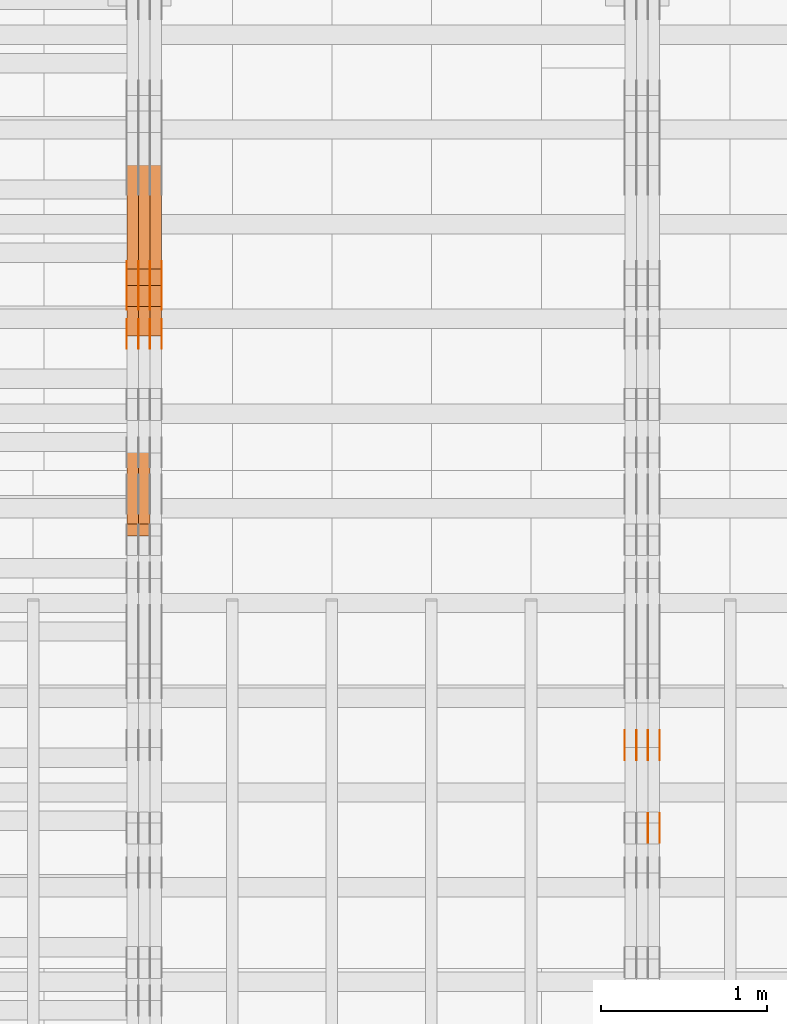
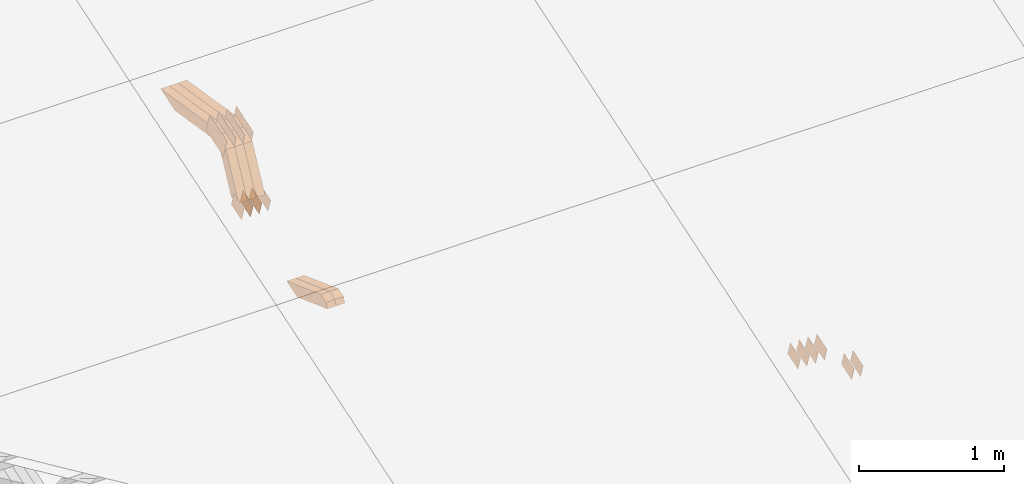
# One storey, part 49 of 385: 28 proxies.
"""IFC2X3 building model written with IfcOpenShell, lengths in millimetres."""

from ifc_helpers import new_model, entity, si_unit, converted_unit, derived_unit, direction, frame, origin, place, context, subcontext, project, spatial, polyline, outline, extrude, source, transform, mapped, material, type_object, type_shapes, element, save


model = new_model("IFC2X3")

# Units and contexts
model_context = context("Model", 3, precision=0.01, world=origin(), true_north=direction((6.12303176911189e-17, 1.0)))
body_context = subcontext(model_context, "Body", "Model", "MODEL_VIEW")
ifc_project = project(units=[si_unit("LENGTHUNIT", "METRE", prefix="MILLI"), si_unit("AREAUNIT", "SQUARE_METRE"), si_unit("VOLUMEUNIT", "CUBIC_METRE"), converted_unit("PLANEANGLEUNIT", "DEGREE", entity("IfcRatioMeasure", 0.0174532925199433), si_unit("PLANEANGLEUNIT", "RADIAN"), dimensions=[0, 0, 0, 0, 0, 0, 0]), si_unit("MASSUNIT", "GRAM", prefix="KILO"), derived_unit("MASSDENSITYUNIT", [(si_unit("MASSUNIT", "GRAM", prefix="KILO"), 1), (si_unit("LENGTHUNIT", "METRE"), -3)]), si_unit("TIMEUNIT", "SECOND"), si_unit("FREQUENCYUNIT", "HERTZ"), si_unit("THERMODYNAMICTEMPERATUREUNIT", "DEGREE_CELSIUS"), derived_unit("THERMALTRANSMITTANCEUNIT", [(si_unit("MASSUNIT", "GRAM", prefix="KILO"), 1), (si_unit("THERMODYNAMICTEMPERATUREUNIT", "KELVIN"), -1), (si_unit("TIMEUNIT", "SECOND"), -3)]), derived_unit("VOLUMETRICFLOWRATEUNIT", [(si_unit("LENGTHUNIT", "METRE"), 3), (si_unit("TIMEUNIT", "SECOND"), -1)]), si_unit("ELECTRICCURRENTUNIT", "AMPERE"), si_unit("ELECTRICVOLTAGEUNIT", "VOLT"), si_unit("POWERUNIT", "WATT"), si_unit("FORCEUNIT", "NEWTON", prefix="KILO"), si_unit("ILLUMINANCEUNIT", "LUX"), si_unit("LUMINOUSFLUXUNIT", "LUMEN"), si_unit("LUMINOUSINTENSITYUNIT", "CANDELA"), derived_unit("USERDEFINED", [(si_unit("MASSUNIT", "GRAM", prefix="KILO"), -1), (si_unit("LENGTHUNIT", "METRE"), -2), (si_unit("TIMEUNIT", "SECOND"), 3), (si_unit("LUMINOUSFLUXUNIT", "LUMEN"), 1)]), derived_unit("LINEARVELOCITYUNIT", [(si_unit("LENGTHUNIT", "METRE"), 1), (si_unit("TIMEUNIT", "SECOND"), -1)]), si_unit("PRESSUREUNIT", "PASCAL"), derived_unit("USERDEFINED", [(si_unit("LENGTHUNIT", "METRE"), -2), (si_unit("MASSUNIT", "GRAM", prefix="KILO"), 1), (si_unit("TIMEUNIT", "SECOND"), -2)])], contexts=[model_context])

# Site, building, storey
site_placement = place(None, origin())
site = spatial("IfcSite", under=ifc_project, at=site_placement, CompositionType="ELEMENT")
building_placement = place(site_placement, origin())
building = spatial("IfcBuilding", under=site, at=building_placement, CompositionType="ELEMENT")
storey_placement = place(building_placement, origin())
storey = spatial("IfcBuildingStorey", under=building, at=storey_placement, Name="Default", CompositionType="ELEMENT", Elevation=0.0)

# Proxies
ifc_material_1 = material(Name="IfcSurfaceStyle #104476")
building_element_proxy_type_1 = type_object("IfcBuildingElementProxyType", PredefinedType="NOTDEFINED", material=ifc_material_1)
shared_shape_1 = source(origin(), body_context, "Body", "SweptSolid", [
    extrude(outline(polyline([(-74.9998565677169, -60.0000596852269), (74.9998794200137, -60.0000596852269), (74.9998565677151, 60.0000596852269), (-74.9998794200119, 60.0000596852269), (-74.9998565677169, -60.0000596852269)])), frame((74.9998794200137, 60.0000596852269, 0.0), z_axis=(0.0, 0.0, 1.0), x_axis=(-1.0, 0.0, 0.0)), (0.0, 0.0, 1.0), 1.3),
])
type_shapes(building_element_proxy_type_1, [shared_shape_1])
proxy_1_placement = place(building_placement, frame((6386.29999999999, 7527.6269081625, 1621.97418552253), z_axis=(-1.0, 0.0, 0.0), x_axis=(0.0, 0.951056516295124, 0.309016994375039)))
element("IfcBuildingElementProxy", 1, at=proxy_1_placement, inside=storey, type_object=building_element_proxy_type_1, material=ifc_material_1, context=body_context, shape_type="MappedRepresentation", body=[
    mapped(shared_shape_1, transform((0.0, 0.0, 0.0), scale=1.0)),
])
ifc_material_2 = material(Name="IfcSurfaceStyle #104419")
building_element_proxy_type_2 = type_object("IfcBuildingElementProxyType", PredefinedType="NOTDEFINED", material=ifc_material_2)
shared_shape_2 = source(origin(), body_context, "Body", "SweptSolid", [
    extrude(outline(polyline([(-74.9998565677169, -60.0000596852269), (74.9998794200137, -60.0000596852269), (74.9998565677151, 60.0000596852269), (-74.9998794200119, 60.0000596852269), (-74.9998565677169, -60.0000596852269)])), frame((74.9998794200137, 60.0000596852269, 0.0), z_axis=(0.0, 0.0, 1.0), x_axis=(-1.0, 0.0, 0.0)), (0.0, 0.0, 1.0), 1.3),
])
type_shapes(building_element_proxy_type_2, [shared_shape_2])
proxy_2_placement = place(building_placement, frame((6315.0, 7527.6269081625, 1621.97418552253), z_axis=(-1.0, 0.0, 0.0), x_axis=(0.0, 0.951056516295124, 0.309016994375039)))
element("IfcBuildingElementProxy", 2, at=proxy_2_placement, inside=storey, type_object=building_element_proxy_type_2, material=ifc_material_2, context=body_context, shape_type="MappedRepresentation", body=[
    mapped(shared_shape_2, transform((0.0, 0.0, 0.0), scale=1.0)),
])
ifc_material_3 = material(Name="IfcSurfaceStyle #104362")
building_element_proxy_type_3 = type_object("IfcBuildingElementProxyType", PredefinedType="NOTDEFINED", material=ifc_material_3)
shared_shape_3 = source(origin(), body_context, "Body", "SweptSolid", [
    extrude(outline(polyline([(-74.9998565677169, -60.0000596852269), (74.9998794200137, -60.0000596852269), (74.9998565677151, 60.0000596852269), (-74.9998794200119, 60.0000596852269), (-74.9998565677169, -60.0000596852269)])), frame((74.9998794200137, 60.0000596852269, 0.0), z_axis=(0.0, 0.0, 1.0), x_axis=(-1.0, 0.0, 0.0)), (0.0, 0.0, 1.0), 1.3),
])
type_shapes(building_element_proxy_type_3, [shared_shape_3])
proxy_3_placement = place(building_placement, frame((6316.29999999999, 7527.6269081625, 1621.97418552253), z_axis=(-1.0, 0.0, 0.0), x_axis=(0.0, 0.951056516295124, 0.309016994375039)))
element("IfcBuildingElementProxy", 3, at=proxy_3_placement, inside=storey, type_object=building_element_proxy_type_3, material=ifc_material_3, context=body_context, shape_type="MappedRepresentation", body=[
    mapped(shared_shape_3, transform((0.0, 0.0, 0.0), scale=1.0)),
])
ifc_material_4 = material(Name="IfcSurfaceStyle #104305")
building_element_proxy_type_4 = type_object("IfcBuildingElementProxyType", PredefinedType="NOTDEFINED", material=ifc_material_4)
shared_shape_4 = source(origin(), body_context, "Body", "SweptSolid", [
    extrude(outline(polyline([(-74.9998565677169, -60.0000596852269), (74.9998794200137, -60.0000596852269), (74.9998565677151, 60.0000596852269), (-74.9998794200119, 60.0000596852269), (-74.9998565677169, -60.0000596852269)])), frame((74.9998794200137, 60.0000596852269, 0.0), z_axis=(0.0, 0.0, 1.0), x_axis=(-1.0, 0.0, 0.0)), (0.0, 0.0, 1.0), 1.29999999999999),
])
type_shapes(building_element_proxy_type_4, [shared_shape_4])
proxy_4_placement = place(building_placement, frame((6245.0, 7527.6269081625, 1621.97418552253), z_axis=(-1.0, 0.0, 0.0), x_axis=(0.0, 0.951056516295124, 0.309016994375039)))
element("IfcBuildingElementProxy", 4, at=proxy_4_placement, inside=storey, type_object=building_element_proxy_type_4, material=ifc_material_4, context=body_context, shape_type="MappedRepresentation", body=[
    mapped(shared_shape_4, transform((0.0, 0.0, 0.0), scale=1.0)),
])
ifc_material_5 = material(Name="IfcSurfaceStyle #104248")
building_element_proxy_type_5 = type_object("IfcBuildingElementProxyType", PredefinedType="NOTDEFINED", material=ifc_material_5)
shared_shape_5 = source(origin(), body_context, "Body", "SweptSolid", [
    extrude(outline(polyline([(-74.9998565677169, -60.0000596852269), (74.9998794200137, -60.0000596852269), (74.9998565677151, 60.0000596852269), (-74.9998794200119, 60.0000596852269), (-74.9998565677169, -60.0000596852269)])), frame((74.9998794200137, 60.0000596852269, 0.0), z_axis=(0.0, 0.0, 1.0), x_axis=(-1.0, 0.0, 0.0)), (0.0, 0.0, 1.0), 1.29999999999999),
])
type_shapes(building_element_proxy_type_5, [shared_shape_5])
proxy_5_placement = place(building_placement, frame((6246.29999999999, 7527.6269081625, 1621.97418552253), z_axis=(-1.0, 0.0, 0.0), x_axis=(0.0, 0.951056516295124, 0.309016994375039)))
element("IfcBuildingElementProxy", 5, at=proxy_5_placement, inside=storey, type_object=building_element_proxy_type_5, material=ifc_material_5, context=body_context, shape_type="MappedRepresentation", body=[
    mapped(shared_shape_5, transform((0.0, 0.0, 0.0), scale=1.0)),
])
ifc_material_6 = material(Name="IfcSurfaceStyle #104191")
building_element_proxy_type_6 = type_object("IfcBuildingElementProxyType", PredefinedType="NOTDEFINED", material=ifc_material_6)
shared_shape_6 = source(origin(), body_context, "Body", "SweptSolid", [
    extrude(outline(polyline([(-74.9998565677169, -60.0000596852269), (74.9998794200137, -60.0000596852269), (74.9998565677151, 60.0000596852269), (-74.9998794200119, 60.0000596852269), (-74.9998565677169, -60.0000596852269)])), frame((74.9998794200137, 60.0000596852269, 0.0), z_axis=(0.0, 0.0, 1.0), x_axis=(-1.0, 0.0, 0.0)), (0.0, 0.0, 1.0), 1.29999999999999),
])
type_shapes(building_element_proxy_type_6, [shared_shape_6])
proxy_6_placement = place(building_placement, frame((6175.0, 7527.6269081625, 1621.97418552253), z_axis=(-1.0, 0.0, 0.0), x_axis=(0.0, 0.951056516295124, 0.309016994375039)))
element("IfcBuildingElementProxy", 6, at=proxy_6_placement, inside=storey, type_object=building_element_proxy_type_6, material=ifc_material_6, context=body_context, shape_type="MappedRepresentation", body=[
    mapped(shared_shape_6, transform((0.0, 0.0, 0.0), scale=1.0)),
])
ifc_material_7 = material(Name="IfcSurfaceStyle #94216")
building_element_proxy_type_7 = type_object("IfcBuildingElementProxyType", PredefinedType="NOTDEFINED", material=ifc_material_7)
shared_shape_7 = source(origin(), body_context, "Body", "SweptSolid", [
    extrude(outline(polyline([(-74.9998565677233, -60.0000596852342), (74.9998794200074, -60.0000596852342), (74.9998565677233, 60.0000596852342), (-74.9998794200074, 60.0000596852342), (-74.9998565677233, -60.0000596852342)])), frame((74.9998794200073, 60.0000596852342, 0.0), z_axis=(0.0, 0.0, 1.0), x_axis=(-1.0, 0.0, 0.0)), (0.0, 0.0, 1.0), 1.3),
])
type_shapes(building_element_proxy_type_7, [shared_shape_7])
proxy_7_placement = place(building_placement, frame((6386.29999999999, 7029.15620503751, 1786.70025974129), z_axis=(-1.0, 0.0, 0.0), x_axis=(0.0, 0.951056516295154, 0.309016994374948)))
element("IfcBuildingElementProxy", 7, at=proxy_7_placement, inside=storey, type_object=building_element_proxy_type_7, material=ifc_material_7, context=body_context, shape_type="MappedRepresentation", body=[
    mapped(shared_shape_7, transform((0.0, 0.0, 0.0), scale=1.0)),
])
ifc_material_8 = material(Name="IfcSurfaceStyle #94159")
building_element_proxy_type_8 = type_object("IfcBuildingElementProxyType", PredefinedType="NOTDEFINED", material=ifc_material_8)
shared_shape_8 = source(origin(), body_context, "Body", "SweptSolid", [
    extrude(outline(polyline([(-74.9998565677233, -60.0000596852342), (74.9998794200074, -60.0000596852342), (74.9998565677233, 60.0000596852342), (-74.9998794200074, 60.0000596852342), (-74.9998565677233, -60.0000596852342)])), frame((74.9998794200073, 60.0000596852342, 0.0), z_axis=(0.0, 0.0, 1.0), x_axis=(-1.0, 0.0, 0.0)), (0.0, 0.0, 1.0), 1.3),
])
type_shapes(building_element_proxy_type_8, [shared_shape_8])
proxy_8_placement = place(building_placement, frame((6315.0, 7029.15620503751, 1786.70025974129), z_axis=(-1.0, 0.0, 0.0), x_axis=(0.0, 0.951056516295154, 0.309016994374948)))
element("IfcBuildingElementProxy", 8, at=proxy_8_placement, inside=storey, type_object=building_element_proxy_type_8, material=ifc_material_8, context=body_context, shape_type="MappedRepresentation", body=[
    mapped(shared_shape_8, transform((0.0, 0.0, 0.0), scale=1.0)),
])
ifc_material_9 = material(Name="IfcSurfaceStyle #72096")
building_element_proxy_type_9 = type_object("IfcBuildingElementProxyType", PredefinedType="NOTDEFINED", material=ifc_material_9)
shared_shape_9 = source(origin(), body_context, "Body", "SweptSolid", [
    extrude(outline(polyline([(-124.999432723313, -83.9999457831645), (125.000177551971, -83.9999457831645), (124.999395001513, 83.9999457831646), (-125.000139830171, 83.9999457831645), (-124.999432723313, -83.9999457831645)])), frame((125.000177551971, 84.0001194377192, 0.0), z_axis=(0.0, 0.0, 1.0), x_axis=(-1.0, 0.0, 0.0)), (0.0, 0.0, 1.0), 1.3),
])
type_shapes(building_element_proxy_type_9, [shared_shape_9])
proxy_9_placement = place(building_placement, frame((3386.29999999999, 10242.0968435406, 2855.88278137571), z_axis=(-1.0, 0.0, 0.0), x_axis=(0.0, 0.951056516295154, 0.309016994374948)))
element("IfcBuildingElementProxy", 9, at=proxy_9_placement, inside=storey, type_object=building_element_proxy_type_9, material=ifc_material_9, context=body_context, shape_type="MappedRepresentation", body=[
    mapped(shared_shape_9, transform((0.0, 0.0, 0.0), scale=1.0)),
])
ifc_material_10 = material(Name="IfcSurfaceStyle #72039")
building_element_proxy_type_10 = type_object("IfcBuildingElementProxyType", PredefinedType="NOTDEFINED", material=ifc_material_10)
shared_shape_10 = source(origin(), body_context, "Body", "SweptSolid", [
    extrude(outline(polyline([(-124.999432723313, -83.9999457831645), (125.000177551971, -83.9999457831645), (124.999395001513, 83.9999457831646), (-125.000139830171, 83.9999457831645), (-124.999432723313, -83.9999457831645)])), frame((125.000177551971, 84.0001194377192, 0.0), z_axis=(0.0, 0.0, 1.0), x_axis=(-1.0, 0.0, 0.0)), (0.0, 0.0, 1.0), 1.3),
])
type_shapes(building_element_proxy_type_10, [shared_shape_10])
proxy_10_placement = place(building_placement, frame((3315.0, 10242.0968435406, 2855.88278137571), z_axis=(-1.0, 0.0, 0.0), x_axis=(0.0, 0.951056516295154, 0.309016994374948)))
element("IfcBuildingElementProxy", 10, at=proxy_10_placement, inside=storey, type_object=building_element_proxy_type_10, material=ifc_material_10, context=body_context, shape_type="MappedRepresentation", body=[
    mapped(shared_shape_10, transform((0.0, 0.0, 0.0), scale=1.0)),
])
ifc_material_11 = material(Name="IfcSurfaceStyle #71982")
building_element_proxy_type_11 = type_object("IfcBuildingElementProxyType", PredefinedType="NOTDEFINED", material=ifc_material_11)
shared_shape_11 = source(origin(), body_context, "Body", "SweptSolid", [
    extrude(outline(polyline([(-124.999432723313, -83.9999457831645), (125.000177551971, -83.9999457831645), (124.999395001513, 83.9999457831646), (-125.000139830171, 83.9999457831645), (-124.999432723313, -83.9999457831645)])), frame((125.000177551971, 84.0001194377192, 0.0), z_axis=(0.0, 0.0, 1.0), x_axis=(-1.0, 0.0, 0.0)), (0.0, 0.0, 1.0), 1.3),
])
type_shapes(building_element_proxy_type_11, [shared_shape_11])
proxy_11_placement = place(building_placement, frame((3316.29999999999, 10242.0968435406, 2855.88278137571), z_axis=(-1.0, 0.0, 0.0), x_axis=(0.0, 0.951056516295154, 0.309016994374948)))
element("IfcBuildingElementProxy", 11, at=proxy_11_placement, inside=storey, type_object=building_element_proxy_type_11, material=ifc_material_11, context=body_context, shape_type="MappedRepresentation", body=[
    mapped(shared_shape_11, transform((0.0, 0.0, 0.0), scale=1.0)),
])
ifc_material_12 = material(Name="IfcSurfaceStyle #71925")
building_element_proxy_type_12 = type_object("IfcBuildingElementProxyType", PredefinedType="NOTDEFINED", material=ifc_material_12)
shared_shape_12 = source(origin(), body_context, "Body", "SweptSolid", [
    extrude(outline(polyline([(-124.999432723313, -83.9999457831645), (125.000177551971, -83.9999457831645), (124.999395001513, 83.9999457831646), (-125.000139830171, 83.9999457831645), (-124.999432723313, -83.9999457831645)])), frame((125.000177551971, 84.0001194377192, 0.0), z_axis=(0.0, 0.0, 1.0), x_axis=(-1.0, 0.0, 0.0)), (0.0, 0.0, 1.0), 1.29999999999998),
])
type_shapes(building_element_proxy_type_12, [shared_shape_12])
proxy_12_placement = place(building_placement, frame((3245.0, 10242.0968435406, 2855.88278137571), z_axis=(-1.0, 0.0, 0.0), x_axis=(0.0, 0.951056516295154, 0.309016994374948)))
element("IfcBuildingElementProxy", 12, at=proxy_12_placement, inside=storey, type_object=building_element_proxy_type_12, material=ifc_material_12, context=body_context, shape_type="MappedRepresentation", body=[
    mapped(shared_shape_12, transform((0.0, 0.0, 0.0), scale=1.0)),
])
ifc_material_13 = material(Name="IfcSurfaceStyle #71868")
building_element_proxy_type_13 = type_object("IfcBuildingElementProxyType", PredefinedType="NOTDEFINED", material=ifc_material_13)
shared_shape_13 = source(origin(), body_context, "Body", "SweptSolid", [
    extrude(outline(polyline([(-124.999432723313, -83.9999457831645), (125.000177551971, -83.9999457831645), (124.999395001513, 83.9999457831646), (-125.000139830171, 83.9999457831645), (-124.999432723313, -83.9999457831645)])), frame((125.000177551971, 84.0001194377192, 0.0), z_axis=(0.0, 0.0, 1.0), x_axis=(-1.0, 0.0, 0.0)), (0.0, 0.0, 1.0), 1.29999999999998),
])
type_shapes(building_element_proxy_type_13, [shared_shape_13])
proxy_13_placement = place(building_placement, frame((3246.29999999999, 10242.0968435406, 2855.88278137571), z_axis=(-1.0, 0.0, 0.0), x_axis=(0.0, 0.951056516295154, 0.309016994374948)))
element("IfcBuildingElementProxy", 13, at=proxy_13_placement, inside=storey, type_object=building_element_proxy_type_13, material=ifc_material_13, context=body_context, shape_type="MappedRepresentation", body=[
    mapped(shared_shape_13, transform((0.0, 0.0, 0.0), scale=1.0)),
])
ifc_material_14 = material(Name="IfcSurfaceStyle #71811")
building_element_proxy_type_14 = type_object("IfcBuildingElementProxyType", PredefinedType="NOTDEFINED", material=ifc_material_14)
shared_shape_14 = source(origin(), body_context, "Body", "SweptSolid", [
    extrude(outline(polyline([(-124.999432723313, -83.9999457831645), (125.000177551971, -83.9999457831645), (124.999395001513, 83.9999457831646), (-125.000139830171, 83.9999457831645), (-124.999432723313, -83.9999457831645)])), frame((125.000177551971, 84.0001194377192, 0.0), z_axis=(0.0, 0.0, 1.0), x_axis=(-1.0, 0.0, 0.0)), (0.0, 0.0, 1.0), 1.29999999999998),
])
type_shapes(building_element_proxy_type_14, [shared_shape_14])
proxy_14_placement = place(building_placement, frame((3175.0, 10242.0968435406, 2855.88278137571), z_axis=(-1.0, 0.0, 0.0), x_axis=(0.0, 0.951056516295154, 0.309016994374948)))
element("IfcBuildingElementProxy", 14, at=proxy_14_placement, inside=storey, type_object=building_element_proxy_type_14, material=ifc_material_14, context=body_context, shape_type="MappedRepresentation", body=[
    mapped(shared_shape_14, transform((0.0, 0.0, 0.0), scale=1.0)),
])
ifc_material_15 = material(Name="IfcSurfaceStyle #70386")
building_element_proxy_type_15 = type_object("IfcBuildingElementProxyType", PredefinedType="NOTDEFINED", material=ifc_material_15)
shared_shape_15 = source(origin(), body_context, "Body", "SweptSolid", [
    extrude(outline(polyline([(-74.9998754286189, -60.0000016373433), (74.9998605591118, -60.0000016373433), (74.9998754286189, 60.0000016373433), (-74.9998605591118, 60.0000016373433), (-74.9998754286189, -60.0000016373433)])), frame((74.9999131819004, 60.0000016373433, 0.0), z_axis=(0.0, 0.0, 1.0), x_axis=(-1.0, 0.0, 0.0)), (0.0, 0.0, 1.0), 1.3),
])
type_shapes(building_element_proxy_type_15, [shared_shape_15])
proxy_15_placement = place(building_placement, frame((3386.29999999999, 10004.8612689908, 2426.87628052724), z_axis=(-1.0, 0.0, 0.0), x_axis=(0.0, 0.951056516295124, 0.309016994375039)))
element("IfcBuildingElementProxy", 15, at=proxy_15_placement, inside=storey, type_object=building_element_proxy_type_15, material=ifc_material_15, context=body_context, shape_type="MappedRepresentation", body=[
    mapped(shared_shape_15, transform((0.0, 0.0, 0.0), scale=1.0)),
])
ifc_material_16 = material(Name="IfcSurfaceStyle #70329")
building_element_proxy_type_16 = type_object("IfcBuildingElementProxyType", PredefinedType="NOTDEFINED", material=ifc_material_16)
shared_shape_16 = source(origin(), body_context, "Body", "SweptSolid", [
    extrude(outline(polyline([(-74.9998754286189, -60.0000016373433), (74.9998605591118, -60.0000016373433), (74.9998754286189, 60.0000016373433), (-74.9998605591118, 60.0000016373433), (-74.9998754286189, -60.0000016373433)])), frame((74.9999131819004, 60.0000016373433, 0.0), z_axis=(0.0, 0.0, 1.0), x_axis=(-1.0, 0.0, 0.0)), (0.0, 0.0, 1.0), 1.3),
])
type_shapes(building_element_proxy_type_16, [shared_shape_16])
proxy_16_placement = place(building_placement, frame((3315.0, 10004.8612689908, 2426.87628052724), z_axis=(-1.0, 0.0, 0.0), x_axis=(0.0, 0.951056516295124, 0.309016994375039)))
element("IfcBuildingElementProxy", 16, at=proxy_16_placement, inside=storey, type_object=building_element_proxy_type_16, material=ifc_material_16, context=body_context, shape_type="MappedRepresentation", body=[
    mapped(shared_shape_16, transform((0.0, 0.0, 0.0), scale=1.0)),
])
ifc_material_17 = material(Name="IfcSurfaceStyle #70272")
building_element_proxy_type_17 = type_object("IfcBuildingElementProxyType", PredefinedType="NOTDEFINED", material=ifc_material_17)
shared_shape_17 = source(origin(), body_context, "Body", "SweptSolid", [
    extrude(outline(polyline([(-74.9998754286189, -60.0000016373433), (74.9998605591118, -60.0000016373433), (74.9998754286189, 60.0000016373433), (-74.9998605591118, 60.0000016373433), (-74.9998754286189, -60.0000016373433)])), frame((74.9999131819004, 60.0000016373433, 0.0), z_axis=(0.0, 0.0, 1.0), x_axis=(-1.0, 0.0, 0.0)), (0.0, 0.0, 1.0), 1.3),
])
type_shapes(building_element_proxy_type_17, [shared_shape_17])
proxy_17_placement = place(building_placement, frame((3316.29999999999, 10004.8612689908, 2426.87628052724), z_axis=(-1.0, 0.0, 0.0), x_axis=(0.0, 0.951056516295124, 0.309016994375039)))
element("IfcBuildingElementProxy", 17, at=proxy_17_placement, inside=storey, type_object=building_element_proxy_type_17, material=ifc_material_17, context=body_context, shape_type="MappedRepresentation", body=[
    mapped(shared_shape_17, transform((0.0, 0.0, 0.0), scale=1.0)),
])
ifc_material_18 = material(Name="IfcSurfaceStyle #70215")
building_element_proxy_type_18 = type_object("IfcBuildingElementProxyType", PredefinedType="NOTDEFINED", material=ifc_material_18)
shared_shape_18 = source(origin(), body_context, "Body", "SweptSolid", [
    extrude(outline(polyline([(-74.9998754286189, -60.0000016373433), (74.9998605591118, -60.0000016373433), (74.9998754286189, 60.0000016373433), (-74.9998605591118, 60.0000016373433), (-74.9998754286189, -60.0000016373433)])), frame((74.9999131819004, 60.0000016373433, 0.0), z_axis=(0.0, 0.0, 1.0), x_axis=(-1.0, 0.0, 0.0)), (0.0, 0.0, 1.0), 1.29999999999999),
])
type_shapes(building_element_proxy_type_18, [shared_shape_18])
proxy_18_placement = place(building_placement, frame((3245.0, 10004.8612689908, 2426.87628052724), z_axis=(-1.0, 0.0, 0.0), x_axis=(0.0, 0.951056516295124, 0.309016994375039)))
element("IfcBuildingElementProxy", 18, at=proxy_18_placement, inside=storey, type_object=building_element_proxy_type_18, material=ifc_material_18, context=body_context, shape_type="MappedRepresentation", body=[
    mapped(shared_shape_18, transform((0.0, 0.0, 0.0), scale=1.0)),
])
ifc_material_19 = material(Name="IfcSurfaceStyle #70158")
building_element_proxy_type_19 = type_object("IfcBuildingElementProxyType", PredefinedType="NOTDEFINED", material=ifc_material_19)
shared_shape_19 = source(origin(), body_context, "Body", "SweptSolid", [
    extrude(outline(polyline([(-74.9998754286189, -60.0000016373433), (74.9998605591118, -60.0000016373433), (74.9998754286189, 60.0000016373433), (-74.9998605591118, 60.0000016373433), (-74.9998754286189, -60.0000016373433)])), frame((74.9999131819004, 60.0000016373433, 0.0), z_axis=(0.0, 0.0, 1.0), x_axis=(-1.0, 0.0, 0.0)), (0.0, 0.0, 1.0), 1.29999999999999),
])
type_shapes(building_element_proxy_type_19, [shared_shape_19])
proxy_19_placement = place(building_placement, frame((3246.29999999999, 10004.8612689908, 2426.87628052724), z_axis=(-1.0, 0.0, 0.0), x_axis=(0.0, 0.951056516295124, 0.309016994375039)))
element("IfcBuildingElementProxy", 19, at=proxy_19_placement, inside=storey, type_object=building_element_proxy_type_19, material=ifc_material_19, context=body_context, shape_type="MappedRepresentation", body=[
    mapped(shared_shape_19, transform((0.0, 0.0, 0.0), scale=1.0)),
])
ifc_material_20 = material(Name="IfcSurfaceStyle #70101")
building_element_proxy_type_20 = type_object("IfcBuildingElementProxyType", PredefinedType="NOTDEFINED", material=ifc_material_20)
shared_shape_20 = source(origin(), body_context, "Body", "SweptSolid", [
    extrude(outline(polyline([(-74.9998754286189, -60.0000016373433), (74.9998605591118, -60.0000016373433), (74.9998754286189, 60.0000016373433), (-74.9998605591118, 60.0000016373433), (-74.9998754286189, -60.0000016373433)])), frame((74.9999131819004, 60.0000016373433, 0.0), z_axis=(0.0, 0.0, 1.0), x_axis=(-1.0, 0.0, 0.0)), (0.0, 0.0, 1.0), 1.29999999999999),
])
type_shapes(building_element_proxy_type_20, [shared_shape_20])
proxy_20_placement = place(building_placement, frame((3175.0, 10004.8612689908, 2426.87628052724), z_axis=(-1.0, 0.0, 0.0), x_axis=(0.0, 0.951056516295124, 0.309016994375039)))
element("IfcBuildingElementProxy", 20, at=proxy_20_placement, inside=storey, type_object=building_element_proxy_type_20, material=ifc_material_20, context=body_context, shape_type="MappedRepresentation", body=[
    mapped(shared_shape_20, transform((0.0, 0.0, 0.0), scale=1.0)),
])
ifc_material_21 = material(Name="IfcSurfaceStyle #50064")
building_element_proxy_type_21 = type_object("IfcBuildingElementProxyType", Name="T1-W5 50062", PredefinedType="NOTDEFINED", material=ifc_material_21)
shared_shape_21 = source(origin(), body_context, "Body", "SweptSolid", [
    extrude(outline(polyline([(-301.214270081322, -47.5000783565111), (303.980395954293, -47.5000783565111), (288.664123931657, 0.000197935560590153), (195.704076557203, 47.4999793887309), (-487.134326361831, 47.4999793887309), (-301.214270081322, -47.5000783565111)])), frame((303.980395954293, 47.5001815410909, 0.0), z_axis=(0.0, 0.0, 1.0), x_axis=(-1.0, 0.0, 0.0)), (0.0, 0.0, 1.0), 70.0),
])
type_shapes(building_element_proxy_type_21, [shared_shape_21])
proxy_21_placement = place(building_placement, frame((3385.0, 10379.2051671398, 2863.91176079486), z_axis=(-1.0, 0.0, 0.0), x_axis=(0.0, 0.987508363398486, -0.1575665961365)))
element("IfcBuildingElementProxy", 21, at=proxy_21_placement, inside=storey, type_object=building_element_proxy_type_21, material=ifc_material_21, Name="T1-W5", context=body_context, shape_type="MappedRepresentation", body=[
    mapped(shared_shape_21, transform((0.0, 0.0, 0.0), scale=1.0)),
])
ifc_material_22 = material(Name="IfcSurfaceStyle #49998")
building_element_proxy_type_22 = type_object("IfcBuildingElementProxyType", Name="T1-W5 49996", PredefinedType="NOTDEFINED", material=ifc_material_22)
shared_shape_22 = source(origin(), body_context, "Body", "SweptSolid", [
    extrude(outline(polyline([(-301.214270081322, -47.5000783565111), (303.980395954293, -47.5000783565111), (288.664123931657, 0.000197935560590153), (195.704076557203, 47.4999793887309), (-487.134326361831, 47.4999793887309), (-301.214270081322, -47.5000783565111)])), frame((303.980395954293, 47.5001815410909, 0.0), z_axis=(0.0, 0.0, 1.0), x_axis=(-1.0, 0.0, 0.0)), (0.0, 0.0, 1.0), 70.0),
])
type_shapes(building_element_proxy_type_22, [shared_shape_22])
proxy_22_placement = place(building_placement, frame((3315.0, 10379.2051671398, 2863.91176079486), z_axis=(-1.0, 0.0, 0.0), x_axis=(0.0, 0.987508363398486, -0.1575665961365)))
element("IfcBuildingElementProxy", 22, at=proxy_22_placement, inside=storey, type_object=building_element_proxy_type_22, material=ifc_material_22, Name="T1-W5", context=body_context, shape_type="MappedRepresentation", body=[
    mapped(shared_shape_22, transform((0.0, 0.0, 0.0), scale=1.0)),
])
ifc_material_23 = material(Name="IfcSurfaceStyle #49932")
building_element_proxy_type_23 = type_object("IfcBuildingElementProxyType", Name="T1-W5 49930", PredefinedType="NOTDEFINED", material=ifc_material_23)
shared_shape_23 = source(origin(), body_context, "Body", "SweptSolid", [
    extrude(outline(polyline([(-301.214270081322, -47.5000783565111), (303.980395954293, -47.5000783565111), (288.664123931657, 0.000197935560590153), (195.704076557203, 47.4999793887309), (-487.134326361831, 47.4999793887309), (-301.214270081322, -47.5000783565111)])), frame((303.980395954293, 47.5001815410909, 0.0), z_axis=(0.0, 0.0, 1.0), x_axis=(-1.0, 0.0, 0.0)), (0.0, 0.0, 1.0), 70.0),
])
type_shapes(building_element_proxy_type_23, [shared_shape_23])
proxy_23_placement = place(building_placement, frame((3245.0, 10379.2051671398, 2863.91176079486), z_axis=(-1.0, 0.0, 0.0), x_axis=(0.0, 0.987508363398486, -0.1575665961365)))
element("IfcBuildingElementProxy", 23, at=proxy_23_placement, inside=storey, type_object=building_element_proxy_type_23, material=ifc_material_23, Name="T1-W5", context=body_context, shape_type="MappedRepresentation", body=[
    mapped(shared_shape_23, transform((0.0, 0.0, 0.0), scale=1.0)),
])
ifc_material_24 = material(Name="IfcSurfaceStyle #49668")
building_element_proxy_type_24 = type_object("IfcBuildingElementProxyType", Name="T1-W37 49666", PredefinedType="NOTDEFINED", material=ifc_material_24)
shared_shape_24 = source(origin(), body_context, "Body", "SweptSolid", [
    extrude(outline(polyline([(111.787482004227, -179.289397746839), (245.990585035629, -179.289397746839), (-64.0177573255029, 131.410401861866), (-131.116409377007, 131.410958895698), (-162.643900337347, 95.757434736113), (111.787482004227, -179.289397746839)])), frame((185.635323570343, 47.5011799885346, 0.0), z_axis=(0.0, 0.0, 1.0), x_axis=(0.706316677358935, 0.707896003156279, 0.0)), (0.0, 0.0, 1.0), 70.0),
])
type_shapes(building_element_proxy_type_24, [shared_shape_24])
proxy_24_placement = place(building_placement, frame((3385.0, 10081.8581176196, 2424.08390440728), z_axis=(-1.0, 0.0, 0.0), x_axis=(0.0, 0.452995827831714, 0.891512635898707)))
element("IfcBuildingElementProxy", 24, at=proxy_24_placement, inside=storey, type_object=building_element_proxy_type_24, material=ifc_material_24, Name="T1-W37", context=body_context, shape_type="MappedRepresentation", body=[
    mapped(shared_shape_24, transform((0.0, 0.0, 0.0), scale=1.0)),
])
ifc_material_25 = material(Name="IfcSurfaceStyle #49602")
building_element_proxy_type_25 = type_object("IfcBuildingElementProxyType", Name="T1-W37 49600", PredefinedType="NOTDEFINED", material=ifc_material_25)
shared_shape_25 = source(origin(), body_context, "Body", "SweptSolid", [
    extrude(outline(polyline([(111.787482004227, -179.289397746839), (245.990585035629, -179.289397746839), (-64.0177573255029, 131.410401861866), (-131.116409377007, 131.410958895698), (-162.643900337347, 95.757434736113), (111.787482004227, -179.289397746839)])), frame((185.635323570343, 47.5011799885346, 0.0), z_axis=(0.0, 0.0, 1.0), x_axis=(0.706316677358935, 0.707896003156279, 0.0)), (0.0, 0.0, 1.0), 70.0),
])
type_shapes(building_element_proxy_type_25, [shared_shape_25])
proxy_25_placement = place(building_placement, frame((3315.0, 10081.8581176196, 2424.08390440728), z_axis=(-1.0, 0.0, 0.0), x_axis=(0.0, 0.452995827831714, 0.891512635898707)))
element("IfcBuildingElementProxy", 25, at=proxy_25_placement, inside=storey, type_object=building_element_proxy_type_25, material=ifc_material_25, Name="T1-W37", context=body_context, shape_type="MappedRepresentation", body=[
    mapped(shared_shape_25, transform((0.0, 0.0, 0.0), scale=1.0)),
])
ifc_material_26 = material(Name="IfcSurfaceStyle #49536")
building_element_proxy_type_26 = type_object("IfcBuildingElementProxyType", Name="T1-W37 49534", PredefinedType="NOTDEFINED", material=ifc_material_26)
shared_shape_26 = source(origin(), body_context, "Body", "SweptSolid", [
    extrude(outline(polyline([(111.787482004227, -179.289397746839), (245.990585035629, -179.289397746839), (-64.0177573255029, 131.410401861866), (-131.116409377007, 131.410958895698), (-162.643900337347, 95.757434736113), (111.787482004227, -179.289397746839)])), frame((185.635323570343, 47.5011799885346, 0.0), z_axis=(0.0, 0.0, 1.0), x_axis=(0.706316677358935, 0.707896003156279, 0.0)), (0.0, 0.0, 1.0), 70.0),
])
type_shapes(building_element_proxy_type_26, [shared_shape_26])
proxy_26_placement = place(building_placement, frame((3245.0, 10081.8581176196, 2424.08390440728), z_axis=(-1.0, 0.0, 0.0), x_axis=(0.0, 0.452995827831714, 0.891512635898707)))
element("IfcBuildingElementProxy", 26, at=proxy_26_placement, inside=storey, type_object=building_element_proxy_type_26, material=ifc_material_26, Name="T1-W37", context=body_context, shape_type="MappedRepresentation", body=[
    mapped(shared_shape_26, transform((0.0, 0.0, 0.0), scale=1.0)),
])
ifc_material_27 = material(Name="IfcSurfaceStyle #48414")
building_element_proxy_type_27 = type_object("IfcBuildingElementProxyType", Name="T1-W25 48412", PredefinedType="NOTDEFINED", material=ifc_material_27)
shared_shape_27 = source(origin(), body_context, "Body", "SweptSolid", [
    extrude(outline(polyline([(-229.232772462784, -47.5001671709529), (214.075939394384, -47.5001671709529), (212.688957821661, -0.000141058964427199), (152.358910178478, 47.5002377004352), (-349.891034931738, 47.5002377004352), (-229.232772462784, -47.5001671709529)])), frame((214.075939394384, 47.5002377004352, 0.0), z_axis=(0.0, 0.0, 1.0), x_axis=(-1.0, 0.0, 0.0)), (0.0, 0.0, 1.0), 70.0),
])
type_shapes(building_element_proxy_type_27, [shared_shape_27])
proxy_27_placement = place(building_placement, frame((3315.0, 8892.81895960242, 2369.29665807578), z_axis=(-1.0, 0.0, 0.0), x_axis=(0.0, 0.938402514401222, -0.345544094097213)))
element("IfcBuildingElementProxy", 27, at=proxy_27_placement, inside=storey, type_object=building_element_proxy_type_27, material=ifc_material_27, Name="T1-W25", context=body_context, shape_type="MappedRepresentation", body=[
    mapped(shared_shape_27, transform((0.0, 0.0, 0.0), scale=1.0)),
])
ifc_material_28 = material(Name="IfcSurfaceStyle #48348")
building_element_proxy_type_28 = type_object("IfcBuildingElementProxyType", Name="T1-W25 48346", PredefinedType="NOTDEFINED", material=ifc_material_28)
shared_shape_28 = source(origin(), body_context, "Body", "SweptSolid", [
    extrude(outline(polyline([(-229.232772462784, -47.5001671709529), (214.075939394384, -47.5001671709529), (212.688957821661, -0.000141058964427199), (152.358910178478, 47.5002377004352), (-349.891034931738, 47.5002377004352), (-229.232772462784, -47.5001671709529)])), frame((214.075939394384, 47.5002377004352, 0.0), z_axis=(0.0, 0.0, 1.0), x_axis=(-1.0, 0.0, 0.0)), (0.0, 0.0, 1.0), 70.0),
])
type_shapes(building_element_proxy_type_28, [shared_shape_28])
proxy_28_placement = place(building_placement, frame((3245.0, 8892.81895960242, 2369.29665807578), z_axis=(-1.0, 0.0, 0.0), x_axis=(0.0, 0.938402514401222, -0.345544094097213)))
element("IfcBuildingElementProxy", 28, at=proxy_28_placement, inside=storey, type_object=building_element_proxy_type_28, material=ifc_material_28, Name="T1-W25", context=body_context, shape_type="MappedRepresentation", body=[
    mapped(shared_shape_28, transform((0.0, 0.0, 0.0), scale=1.0)),
])

save(model, "model.ifc")
